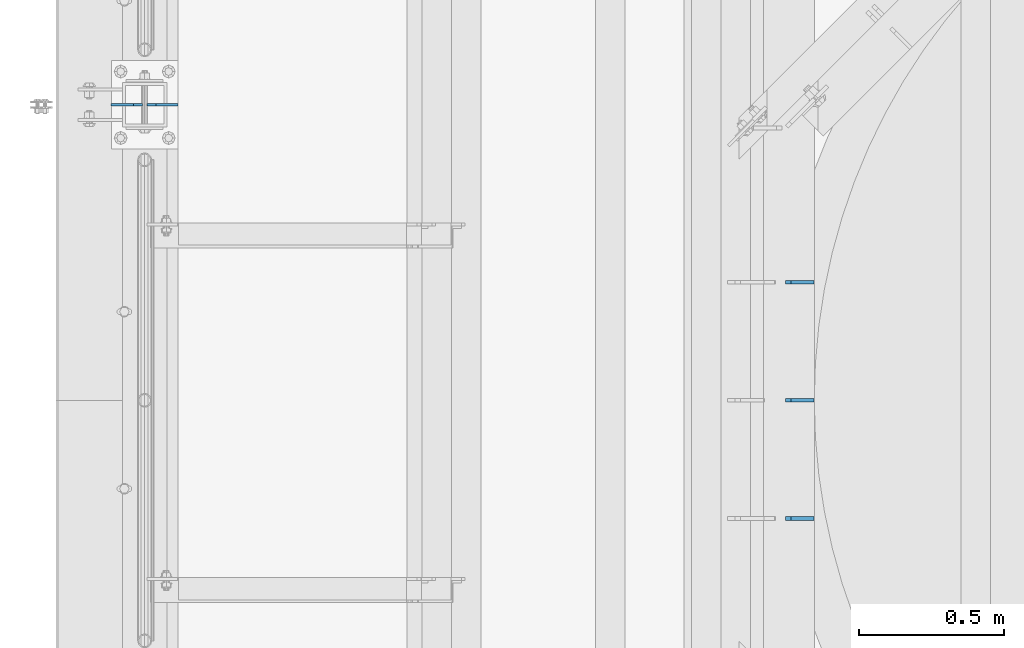
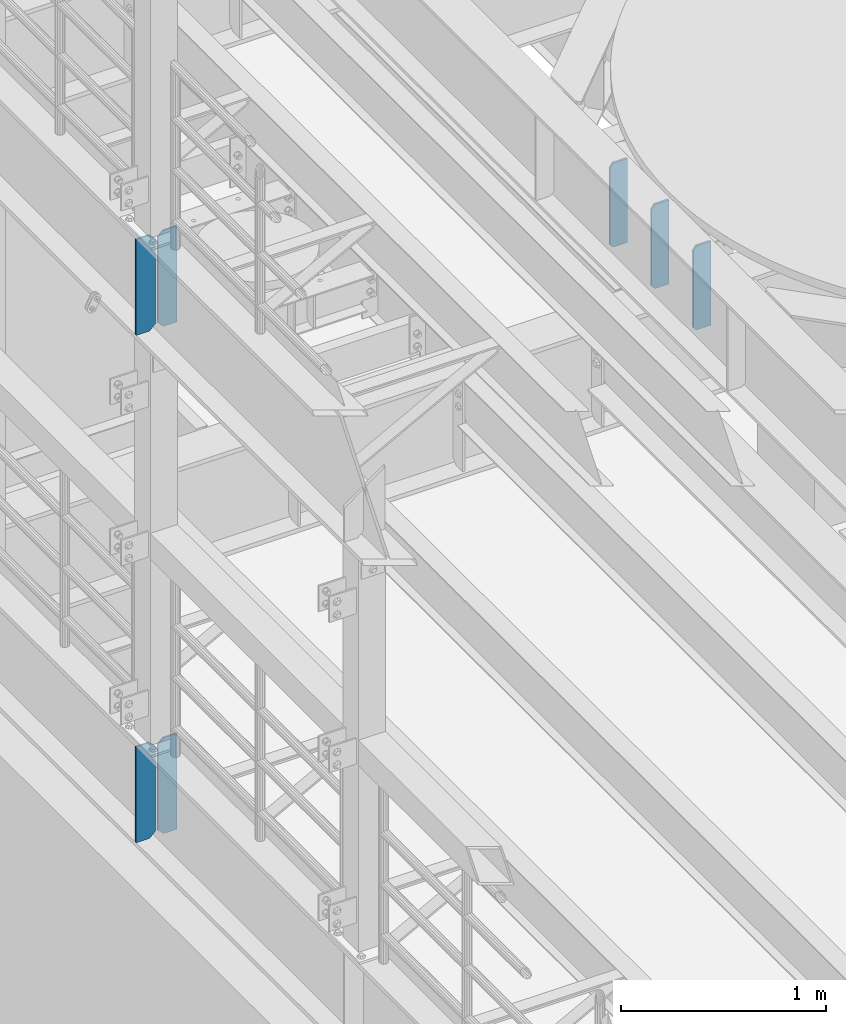
# One storey, part 1538 of 1876: 7 plates, 3 elements without a shape of their own.
"""IFC2X3 building model written with IfcOpenShell, lengths in millimetres."""

from ifc_helpers import new_model, si_unit, frame, origin_with_axes, place, context, subcontext, project, spatial, faceted_brep, material, type_object, element, aggregate, save


model = new_model("IFC2X3")

# Units and contexts
model_context = context("Model", 3, precision=1e-05, world=origin_with_axes())
body_context = subcontext(model_context, "Body", "Model", "MODEL_VIEW")
ifc_project = project(units=[si_unit("LENGTHUNIT", "METRE", prefix="MILLI"), si_unit("AREAUNIT", "SQUARE_METRE"), si_unit("VOLUMEUNIT", "CUBIC_METRE"), si_unit("MASSUNIT", "GRAM", prefix="KILO"), si_unit("TIMEUNIT", "SECOND"), si_unit("PLANEANGLEUNIT", "RADIAN"), si_unit("SOLIDANGLEUNIT", "STERADIAN"), si_unit("THERMODYNAMICTEMPERATUREUNIT", "DEGREE_CELSIUS"), si_unit("LUMINOUSINTENSITYUNIT", "LUMEN")], contexts=[model_context])

# Site, building, storey
site_placement = place(None, origin_with_axes())
site = spatial("IfcSite", under=ifc_project, at=site_placement, CompositionType="ELEMENT")
building_placement = place(site_placement, origin_with_axes())
building = spatial("IfcBuilding", under=site, at=building_placement, Name="Undefined", CompositionType="ELEMENT")
storey_placement = place(building_placement, origin_with_axes())
storey = spatial("IfcBuildingStorey", under=building, at=storey_placement, Name="Undefined", CompositionType="ELEMENT", Elevation=0.0)

# Assembly, plates
assembly_1_placement = place(storey_placement, origin_with_axes())
assembly_1 = element("IfcElementAssembly", 1, at=assembly_1_placement, inside=storey, Name="BEAM", AssemblyPlace="NOTDEFINED", PredefinedType="RIGID_FRAME")
ifc_material = material(Name="STEEL/A36")
plate_type_1 = type_object("IfcPlateType", PredefinedType="NOTDEFINED")
plate_1_placement = place(assembly_1_placement, frame((2301.08125, -1930.39999359133, 7634.2875), z_axis=(0.0, 0.0, 1.0), x_axis=(-1.0, 0.0, 0.0)))
plate_1 = element("IfcPlate", 2, at=plate_1_placement, type_object=plate_type_1, material=ifc_material, Name="PLATE", context=body_context, shape_type="Brep", body=[
    faceted_brep([(0.0, -6.35000000000036, 0.0), (0.0, -6.34999999999991, 501.649993896484), (0.0, 6.34999999999991, 501.649993896484), (0.0, 6.35000000000036, 0.0), (79.3750038146973, -6.34999999999991, 501.649993896484), (79.3750038146973, 6.34999999999991, 501.649993896484), (98.4250030517578, -6.34999999999991, 476.249994277954), (98.4250030517578, 6.34999999999991, 476.249994277954), (98.4250030517578, -6.34999999999991, 19.0499992370605), (98.4250030517578, 6.34999999999991, 19.0499992370605), (79.3750038146973, -6.34999999999991, 0.0), (79.3750038146973, 6.34999999999991, 0.0)], [[[0, 1, 2, 3]], [[1, 4, 5, 2]], [[4, 6, 7, 5]], [[6, 8, 9, 7]], [[8, 10, 11, 9]], [[10, 0, 3, 11]], [[5, 7, 9, 11, 3, 2]], [[10, 8, 6, 4, 1, 0]]]),
])
plate_2_placement = place(assembly_1_placement, frame((2301.08125, -1523.99999359133, 7634.2875), z_axis=(0.0, 0.0, 1.0), x_axis=(-1.0, 0.0, 0.0)))
plate_2 = element("IfcPlate", 3, at=plate_2_placement, type_object=plate_type_1, material=ifc_material, Name="PLATE", context=body_context, shape_type="Brep", body=[
    faceted_brep([(0.0, -6.35000000000036, 0.0), (0.0, -6.34999999999991, 501.649993896484), (0.0, 6.34999999999991, 501.649993896484), (0.0, 6.35000000000036, 0.0), (79.3750038146973, -6.34999999999991, 501.649993896484), (79.3750038146973, 6.34999999999991, 501.649993896484), (98.4250030517578, -6.34999999999991, 476.249994277954), (98.4250030517578, 6.34999999999991, 476.249994277954), (98.4250030517578, -6.34999999999991, 19.0499992370605), (98.4250030517578, 6.34999999999991, 19.0499992370605), (79.3750038146973, -6.34999999999991, 0.0), (79.3750038146973, 6.34999999999991, 0.0)], [[[0, 1, 2, 3]], [[1, 4, 5, 2]], [[4, 6, 7, 5]], [[6, 8, 9, 7]], [[8, 10, 11, 9]], [[10, 0, 3, 11]], [[5, 7, 9, 11, 3, 2]], [[10, 8, 6, 4, 1, 0]]]),
])
plate_3_placement = place(assembly_1_placement, frame((2301.08125, -1117.59999359133, 7634.2875), z_axis=(0.0, 0.0, 1.0), x_axis=(-1.0, 0.0, 0.0)))
plate_3 = element("IfcPlate", 4, at=plate_3_placement, type_object=plate_type_1, material=ifc_material, Name="PLATE", context=body_context, shape_type="Brep", body=[
    faceted_brep([(0.0, -6.35000000000036, 0.0), (0.0, -6.34999999999991, 501.649993896484), (0.0, 6.34999999999991, 501.649993896484), (0.0, 6.35000000000036, 0.0), (79.3750038146973, -6.34999999999991, 501.649993896484), (79.3750038146973, 6.34999999999991, 501.649993896484), (98.4250030517578, -6.34999999999991, 476.249994277954), (98.4250030517578, 6.34999999999991, 476.249994277954), (98.4250030517578, -6.34999999999991, 19.0499992370605), (98.4250030517578, 6.34999999999991, 19.0499992370605), (79.3750038146973, -6.34999999999991, 0.0), (79.3750038146973, 6.34999999999991, 0.0)], [[[0, 1, 2, 3]], [[1, 4, 5, 2]], [[4, 6, 7, 5]], [[6, 8, 9, 7]], [[8, 10, 11, 9]], [[10, 0, 3, 11]], [[5, 7, 9, 11, 3, 2]], [[10, 8, 6, 4, 1, 0]]]),
])
aggregate(assembly_1, [plate_1, plate_2, plate_3])

assembly_2_placement = place(storey_placement, origin_with_axes())
assembly_2 = element("IfcElementAssembly", 5, at=assembly_2_placement, inside=storey, Name="BEAM", AssemblyPlace="NOTDEFINED", PredefinedType="RIGID_FRAME")
plate_type_2 = type_object("IfcPlateType", PredefinedType="NOTDEFINED")
plate_4_placement = place(assembly_2_placement, frame((115.09375, -508.000000000001, 7556.5), z_axis=(0.0, 0.0, 1.0), x_axis=(-1.0, 0.0, 0.0)))
plate_4 = element("IfcPlate", 6, at=plate_4_placement, type_object=plate_type_2, material=ifc_material, Name="PLATE", context=body_context, shape_type="Brep", body=[
    faceted_brep([(0.0, -4.76249999999982, 0.0), (0.0, -4.76249999999982, 571.5), (0.0, 4.76249999999982, 571.5), (0.0, 4.76249999999982, 0.0), (76.1999969482422, -4.76249999999982, 571.5), (76.1999969482422, 4.76249999999982, 571.5), (107.949996948242, -4.76249999999982, 539.75), (107.949996948242, 4.76249999999982, 539.75), (107.949996948242, -4.76249999999982, 31.75), (107.949996948242, 4.76249999999982, 31.75), (76.1999969482422, -4.76250000000073, 0.0), (76.1999969482422, 4.76250000000073, 0.0)], [[[0, 1, 2, 3]], [[1, 4, 5, 2]], [[4, 6, 7, 5]], [[6, 8, 9, 7]], [[8, 10, 11, 9]], [[10, 0, 3, 11]], [[5, 7, 9, 11, 3, 2]], [[10, 8, 6, 4, 1, 0]]]),
])
plate_5_placement = place(assembly_2_placement, frame((-7.14374999999999, -508.000000000001, 7556.5), z_axis=(0.0, 0.0, 1.0), x_axis=(-1.0, 0.0, 0.0)))
plate_5 = element("IfcPlate", 7, at=plate_5_placement, type_object=plate_type_2, material=ifc_material, Name="PLATE", context=body_context, shape_type="Brep", body=[
    faceted_brep([(-9.76996261670138e-14, -4.76250000000073, 31.75), (0.0, -4.76249999999982, 539.75), (0.0, 4.76249999999982, 539.75), (-9.76996261670138e-14, 4.76250000000073, 31.75), (31.75, -4.76249999999982, 571.5), (31.75, 4.76249999999982, 571.5), (107.949996948242, -4.76249999999982, 571.5), (107.949996948242, 4.76249999999982, 571.5), (107.950006484985, -4.76250000000073, 0.0), (107.950006484985, 4.76250000000073, 0.0), (31.75, -4.76250000000073, 0.0), (31.75, 4.76250000000073, 0.0)], [[[0, 1, 2, 3]], [[1, 4, 5, 2]], [[4, 6, 7, 5]], [[6, 8, 9, 7]], [[8, 10, 11, 9]], [[10, 0, 3, 11]], [[5, 7, 9, 11, 3, 2]], [[10, 8, 6, 4, 1, 0]]]),
])
aggregate(assembly_2, [plate_4, plate_5])

assembly_3_placement = place(storey_placement, origin_with_axes())
assembly_3 = element("IfcElementAssembly", 8, at=assembly_3_placement, inside=storey, Name="BEAM", AssemblyPlace="NOTDEFINED", PredefinedType="RIGID_FRAME")
plate_6_placement = place(assembly_3_placement, frame((115.09375, -508.0, 4533.9), z_axis=(0.0, 0.0, 1.0), x_axis=(-1.0, 0.0, 0.0)))
plate_6 = element("IfcPlate", 9, at=plate_6_placement, type_object=plate_type_2, material=ifc_material, Name="PLATE", context=body_context, shape_type="Brep", body=[
    faceted_brep([(0.0, -4.76249999999982, 0.0), (0.0, -4.76249999999982, 571.5), (0.0, 4.76249999999982, 571.5), (0.0, 4.76249999999982, 0.0), (76.1999969482422, -4.76249999999982, 571.5), (76.1999969482422, 4.76249999999982, 571.5), (107.949996948242, -4.76249999999982, 539.75), (107.949996948242, 4.76249999999982, 539.75), (107.949996948242, -4.76249999999982, 31.75), (107.949996948242, 4.76249999999982, 31.75), (76.1999969482422, -4.76250000000073, 0.0), (76.1999969482422, 4.76250000000073, 0.0)], [[[0, 1, 2, 3]], [[1, 4, 5, 2]], [[4, 6, 7, 5]], [[6, 8, 9, 7]], [[8, 10, 11, 9]], [[10, 0, 3, 11]], [[5, 7, 9, 11, 3, 2]], [[10, 8, 6, 4, 1, 0]]]),
])
plate_7_placement = place(assembly_3_placement, frame((-7.14374999999999, -508.0, 4533.9), z_axis=(0.0, 0.0, 1.0), x_axis=(-1.0, 0.0, 0.0)))
plate_7 = element("IfcPlate", 10, at=plate_7_placement, type_object=plate_type_2, material=ifc_material, Name="PLATE", context=body_context, shape_type="Brep", body=[
    faceted_brep([(-9.76996261670138e-14, -4.76250000000073, 31.75), (0.0, -4.76249999999982, 539.75), (0.0, 4.76249999999982, 539.75), (-9.76996261670138e-14, 4.76250000000073, 31.75), (31.75, -4.76249999999982, 571.5), (31.75, 4.76249999999982, 571.5), (107.949996948242, -4.76249999999982, 571.5), (107.949996948242, 4.76249999999982, 571.5), (107.950006484985, -4.76250000000073, 0.0), (107.950006484985, 4.76250000000073, 0.0), (31.75, -4.76250000000073, 0.0), (31.75, 4.76250000000073, 0.0)], [[[0, 1, 2, 3]], [[1, 4, 5, 2]], [[4, 6, 7, 5]], [[6, 8, 9, 7]], [[8, 10, 11, 9]], [[10, 0, 3, 11]], [[5, 7, 9, 11, 3, 2]], [[10, 8, 6, 4, 1, 0]]]),
])
aggregate(assembly_3, [plate_6, plate_7])

save(model, "model.ifc")
